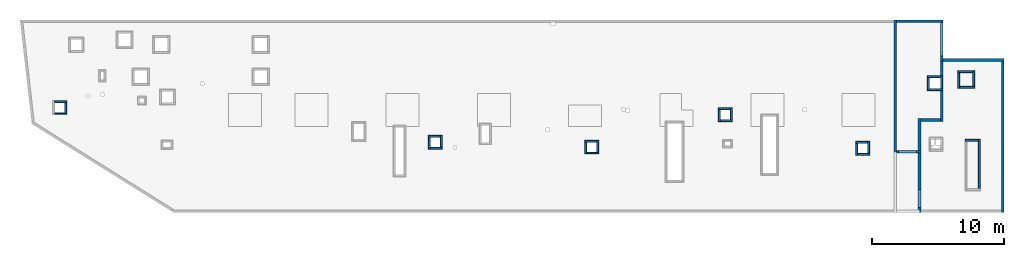
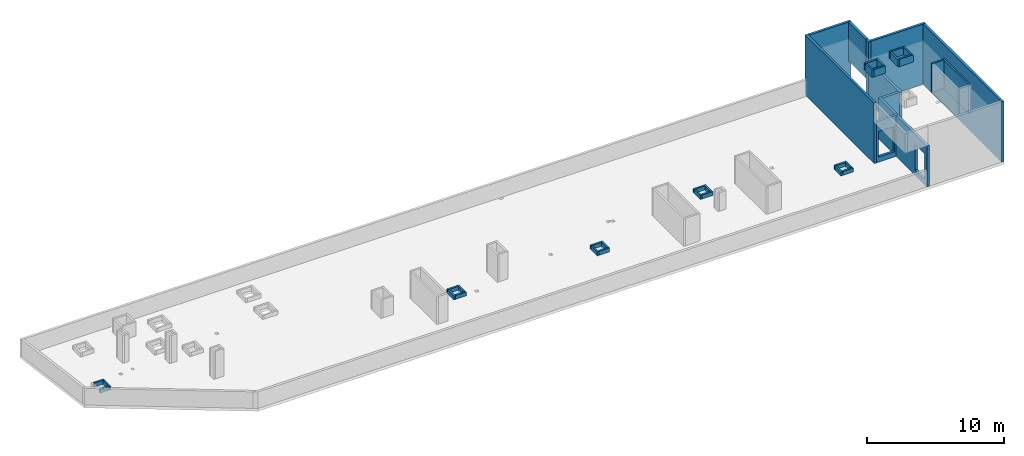
# One storey, part 3 of 3: 40 walls, 2 openings.
"""IFC4 building model written with IfcOpenShell, lengths in millimetres."""

from ifc_helpers import new_model, entity, si_unit, converted_unit, derived_unit, direction, frame, origin, place, context, subcontext, project, spatial, indexed_curve, outline, extrude, polygons, material, type_object, element, save


model = new_model("IFC4")

# Units and contexts
model_context = context("Model", 3, precision=0.01, world=origin(), true_north=direction((6.12303176911189e-17, 1.0)))
plan_context = context("Plan", 3, precision=0.01, world=origin(), true_north=direction((6.12303176911189e-17, 1.0)))
body_context = subcontext(model_context, "Body", "Model", "MODEL_VIEW")
ifc_project = project(units=[si_unit("LENGTHUNIT", "METRE", prefix="MILLI"), si_unit("AREAUNIT", "SQUARE_METRE"), si_unit("VOLUMEUNIT", "CUBIC_METRE"), converted_unit("PLANEANGLEUNIT", "DEGREE", entity("IfcRatioMeasure", 0.0174532925199433), si_unit("PLANEANGLEUNIT", "RADIAN"), dimensions=[0, 0, 0, 0, 0, 0, 0]), si_unit("MASSUNIT", "GRAM", prefix="KILO"), derived_unit("MASSDENSITYUNIT", [(si_unit("MASSUNIT", "GRAM", prefix="KILO"), 1), (si_unit("LENGTHUNIT", "METRE"), -3)]), derived_unit("MOMENTOFINERTIAUNIT", [(si_unit("LENGTHUNIT", "METRE"), 4)]), si_unit("TIMEUNIT", "SECOND"), si_unit("FREQUENCYUNIT", "HERTZ"), si_unit("THERMODYNAMICTEMPERATUREUNIT", "DEGREE_CELSIUS"), derived_unit("THERMALTRANSMITTANCEUNIT", [(si_unit("MASSUNIT", "GRAM", prefix="KILO"), 1), (si_unit("THERMODYNAMICTEMPERATUREUNIT", "KELVIN"), -1), (si_unit("TIMEUNIT", "SECOND"), -3)]), derived_unit("VOLUMETRICFLOWRATEUNIT", [(si_unit("LENGTHUNIT", "METRE"), 3), (si_unit("TIMEUNIT", "SECOND"), -1)]), derived_unit("MASSFLOWRATEUNIT", [(si_unit("MASSUNIT", "GRAM", prefix="KILO"), 1), (si_unit("TIMEUNIT", "SECOND"), -1)]), derived_unit("ROTATIONALFREQUENCYUNIT", [(si_unit("TIMEUNIT", "SECOND"), -1)]), si_unit("ELECTRICCURRENTUNIT", "AMPERE"), si_unit("ELECTRICVOLTAGEUNIT", "VOLT"), si_unit("POWERUNIT", "WATT"), si_unit("FORCEUNIT", "NEWTON", prefix="KILO"), si_unit("ILLUMINANCEUNIT", "LUX"), si_unit("LUMINOUSFLUXUNIT", "LUMEN"), si_unit("LUMINOUSINTENSITYUNIT", "CANDELA"), derived_unit("USERDEFINED", [(si_unit("MASSUNIT", "GRAM", prefix="KILO"), -1), (si_unit("LENGTHUNIT", "METRE"), -2), (si_unit("TIMEUNIT", "SECOND"), 3), (si_unit("LUMINOUSFLUXUNIT", "LUMEN"), 1)]), derived_unit("LINEARVELOCITYUNIT", [(si_unit("LENGTHUNIT", "METRE"), 1), (si_unit("TIMEUNIT", "SECOND"), -1)]), si_unit("PRESSUREUNIT", "PASCAL"), derived_unit("USERDEFINED", [(si_unit("LENGTHUNIT", "METRE"), -2), (si_unit("MASSUNIT", "GRAM", prefix="KILO"), 1), (si_unit("TIMEUNIT", "SECOND"), -2)]), derived_unit("LINEARFORCEUNIT", [(si_unit("MASSUNIT", "GRAM", prefix="KILO"), 1), (si_unit("LENGTHUNIT", "METRE"), 1), (si_unit("TIMEUNIT", "SECOND"), -2), (si_unit("LENGTHUNIT", "METRE"), -1)]), derived_unit("PLANARFORCEUNIT", [(si_unit("MASSUNIT", "GRAM", prefix="KILO"), 1), (si_unit("LENGTHUNIT", "METRE"), 1), (si_unit("TIMEUNIT", "SECOND"), -2), (si_unit("LENGTHUNIT", "METRE"), -2)])], contexts=[model_context, plan_context])

# Site, building, storey
site_placement = place(None, origin())
site = spatial("IfcSite", under=ifc_project, at=site_placement, CompositionType="ELEMENT")
building_placement = place(site_placement, origin())
building = spatial("IfcBuilding", under=site, at=building_placement, CompositionType="ELEMENT")
storey_placement = place(building_placement, frame((0.0, 0.0, 32250.0)))
storey = spatial("IfcBuildingStorey", under=building, at=storey_placement, CompositionType="ELEMENT", Elevation=32250.0)

# Walls
ifc_material = material()
wall_type_1 = type_object("IfcWallType", Name=":ADSK_ 25_200", PredefinedType="STANDARD")
wall_1_placement = place(storey_placement, frame((68870.0, 20300.0, 1910.0), z_axis=(0.0, 0.0, 1.0), x_axis=(0.0, -1.0, 0.0)))
element("IfcWall", 1, at=wall_1_placement, inside=storey, type_object=wall_type_1, material=ifc_material, Name=":ADSK_ 25_200", ObjectType=":ADSK_ 25_200", PredefinedType="NOTDEFINED", context=body_context, shape_type="SweptSolid", body=[
    extrude(outline(indexed_curve([(2520.0006393672, 100.000000000003), (-3.30646371005458e-13, 100.000000000003), (3.30646371005458e-13, -100.000000000003), (2520.0006393672, -100.000000000004), (2520.0006393672, 100.000000000003)], self_intersect=False)), origin(), (0.0, 0.0, 1.0), 3460.0),
])
wall_2_placement = place(storey_placement, frame((68970.0, 17470.0, 0.0)))
element("IfcWall", 2, at=wall_2_placement, inside=storey, type_object=wall_type_1, material=ifc_material, Name=":ADSK_ 25_200", ObjectType=":ADSK_ 25_200", PredefinedType="NOTDEFINED", context=body_context, shape_type="SweptSolid", body=[
    extrude(outline(indexed_curve([(4599.9991821289, 99.9999999999989), (-3.29568315339594e-13, 99.9999999999989), (3.29568315339594e-13, -99.9999999999989), (4599.9991821289, -99.9999999999989), (4599.9991821289, 99.9999999999989)], self_intersect=False)), origin(), (0.0, 0.0, 1.0), 5370.0),
])
wall_3_placement = place(storey_placement, frame((73470.0, 17370.0, 0.0), z_axis=(0.0, 0.0, 1.0), x_axis=(0.0, -1.0, 0.0)))
element("IfcWall", 3, at=wall_3_placement, inside=storey, type_object=wall_type_1, material=ifc_material, Name=":ADSK_ 25_200", ObjectType=":ADSK_ 25_200", PredefinedType="NOTDEFINED", context=body_context, shape_type="SweptSolid", body=[
    extrude(outline(indexed_curve([(11440.0, 100.000000000003), (-1.48847715367481e-13, 100.000000000003), (1.48847715367481e-13, -100.000000000003), (11440.0, -100.000000000004), (11440.0, 100.000000000003)], self_intersect=False)), origin(), (0.0, 0.0, 1.0), 5370.0),
])
wall_4_placement = place(storey_placement, frame((65330.0, 20500.0, 0.0), z_axis=(0.0, 0.0, 1.0), x_axis=(0.0, -1.0, 0.0)))
element("IfcWall", 4, at=wall_4_placement, inside=storey, type_object=wall_type_1, material=ifc_material, Name=":ADSK_ 25_200", ObjectType=":ADSK_ 25_200", PredefinedType="NOTDEFINED", context=body_context, shape_type="SweptSolid", body=[
    extrude(outline(indexed_curve([(10075.0006393667, 100.000000000004), (-2.66139747748769e-13, 100.000000000003), (2.66139747748769e-13, -100.000000000003), (10075.0006393667, -100.000000000002), (10075.0006393667, 100.000000000004)], self_intersect=False)), origin(), (0.0, 0.0, 1.0), 5370.0),
])
wall_5_placement = place(storey_placement, frame((65430.0, 20400.0, -250.0)))
element("IfcWall", 5, at=wall_5_placement, inside=storey, type_object=wall_type_1, material=ifc_material, Name=":ADSK_ 25_200", ObjectType=":ADSK_ 25_200", PredefinedType="NOTDEFINED", context=body_context, shape_type="SweptSolid", body=[
    extrude(outline(indexed_curve([(3540.00000000006, 99.9999999999974), (-3.22401824874843e-13, 99.9999999999989), (3.22401824874843e-13, -99.9999999999989), (3540.00000000006, -100.000000000001), (3540.00000000006, 99.9999999999974)], self_intersect=False)), origin(), (0.0, 0.0, 1.0), 5620.0),
])

# Wall, opening
wall_6_placement = place(storey_placement, frame((65430.0, 10525.0, 0.0)))
wall_6 = element("IfcWall", 6, at=wall_6_placement, inside=storey, type_object=wall_type_1, material=ifc_material, Name=":ADSK_ 25_200", ObjectType=":ADSK_ 25_200", PredefinedType="NOTDEFINED", context=body_context, shape_type="Tessellation", body=[
    polygons([(-3.15235560919963e-12, -99.9999999999989, 0.0), (1649.99999999999, -99.9999999999989, 0.0), (1849.99999999999, -99.9999999999989, 0.0), (1849.99999999999, -99.9999999999989, 3650.0), (1649.99999999999, -99.9999999999989, 3650.0), (4.88252665971232e-11, -99.9999999999989, 3650.0), (150.000000000006, -99.9999999999989, 2729.99999999805), (1500.00000000001, -99.9999999999989, 2729.99999999805), (1500.0, -99.9999999999989, 450.000000000002), (150.000000000006, -99.9999999999989, 450.000000000002), (1849.99999999999, 100.000000000001, 0.0), (1650.00000000009, 100.000000000001, 0.0), (-3.87761424809092e-12, 100.000000000003, 0.0), (-3.87761424809091e-12, 100.000000000001, 3650.0), (1650.00000000009, 100.000000000001, 3650.0), (1849.99999999999, 100.000000000001, 3650.0), (1500.0, 100.000000000001, 2729.99999999805), (149.999999999997, 100.000000000001, 2729.99999999805), (149.999999999997, 100.000000000001, 450.000000000002), (1500.0, 100.000000000001, 450.000000000002), (-3.51498492864527e-12, 2.16573425859679e-12, 3650.0)], [[[1, 2, 3, 4, 5, 6], [7, 8, 9, 10]], [[11, 12, 13, 14, 15, 16], [17, 18, 19, 20]], [[3, 2, 1, 13, 12, 11]], [[1, 6, 21, 14, 13]], [[4, 3, 11, 16]], [[6, 5, 4, 16, 15, 14, 21]], [[17, 8, 7, 18]], [[18, 7, 10, 19]], [[19, 10, 9, 20]], [[8, 17, 20, 9]]], closed=True),
])
opening_1_placement = place(wall_6_placement, frame((-65430.0, -10525.0, 0.0)))
element("IfcOpeningElement", 7, at=opening_1_placement, cuts=wall_6, Name=":ADSK_ 25_200", PredefinedType="OPENING", context=body_context, shape_type="SweptSolid", body=[
    extrude(outline(indexed_curve([(-1139.99999999902, -674.999999999994), (1139.99999999902, -674.999999999994), (1139.99999999902, 675.000000000003), (-1139.99999999902, 675.000000000003), (-1139.99999999902, -674.999999999994)], self_intersect=False)), frame((66255.0, 10325.0, 1590.0), z_axis=(0.0, 1.0, 0.0), x_axis=(0.0, 0.0, -1.0)), (0.0, 0.0, 1.0), 400.000000001943),
])

wall_7_placement = place(storey_placement, frame((67180.0, 5930.0, 0.0), z_axis=(0.0, 0.0, 1.0), x_axis=(0.0, 1.0, 0.0)))
wall_7 = element("IfcWall", 8, at=wall_7_placement, inside=storey, type_object=wall_type_1, material=ifc_material, Name=":ADSK_ 25_200", ObjectType=":ADSK_ 25_200", PredefinedType="NOTDEFINED", context=body_context, shape_type="Tessellation", body=[
    polygons([(1.08286712929839e-12, -99.9999999999946, 0.0), (200.000000000001, -99.9999999999946, 0.0), (4495.00000000053, -99.9999999999946, 0.0), (4495.00000000053, -99.9999999999946, 3650.0), (199.999999999995, -99.9999999999946, 3650.0), (0.0, -99.9999999999946, 3650.0), (384.999999999998, -99.9999999999946, 2729.99999999805), (1735.0, -99.9999999999946, 2729.99999999805), (1735.0, -99.9999999999946, 450.000000000002), (384.999999999999, -99.9999999999946, 450.000000000002), (4495.00000000053, 100.000000000012, 0.0), (200.000000000001, 100.000000000003, 0.0), (2.16573425859679e-12, 100.000000000012, 0.0), (2.16573425859679e-12, 100.000000000003, 1470.0), (1.08286712929839e-12, 100.000000000012, 3650.0), (199.999999999995, 100.000000000012, 3650.0), (4495.00000000053, 100.000000000012, 3650.0), (1735.0, 100.000000000012, 2729.99999999805), (384.999999999999, 100.000000000012, 2729.99999999805), (384.999999999999, 100.000000000012, 450.000000000002), (1735.0, 100.000000000012, 450.000000000002), (0.0, 0.0, 3650.0)], [[[1, 2, 3, 4, 5, 6], [7, 8, 9, 10]], [[11, 12, 13, 14, 15, 16, 17], [18, 19, 20, 21]], [[3, 2, 1, 13, 12, 11]], [[4, 3, 11, 17]], [[6, 22, 15, 14, 13, 1]], [[15, 22, 6, 5, 16]], [[5, 4, 17, 16]], [[7, 19, 18, 8]], [[8, 18, 21, 9]], [[9, 21, 20, 10]], [[19, 7, 10, 20]]], closed=True),
])
opening_2_placement = place(wall_7_placement, frame((-5930.0, 67180.0, 0.0), z_axis=(0.0, 0.0, 1.0), x_axis=(0.0, -1.0, 0.0)))
element("IfcOpeningElement", 9, at=opening_2_placement, cuts=wall_7, Name=":ADSK_ 25_200", PredefinedType="OPENING", context=body_context, shape_type="SweptSolid", body=[
    extrude(outline(indexed_curve([(-674.999999999999, -1139.99999999902), (675.0, -1139.99999999902), (675.0, 1139.99999999902), (-674.999999999999, 1139.99999999902), (-674.999999999999, -1139.99999999902)], self_intersect=False)), frame((67380.0, 6990.0, 1590.0), z_axis=(-1.0, 0.0, 0.0), x_axis=(0.0, 1.0, 0.0)), (0.0, 0.0, 1.0), 400.000000001936),
])

# Walls
wall_8_placement = place(storey_placement, frame((68870.0, 17780.0, -250.0), z_axis=(0.0, 0.0, 1.0), x_axis=(0.0, -1.0, 0.0)))
element("IfcWall", 10, at=wall_8_placement, inside=storey, type_object=wall_type_1, material=ifc_material, Name=":ADSK_ 25_200", ObjectType=":ADSK_ 25_200", PredefinedType="NOTDEFINED", context=body_context, shape_type="Tessellation", body=[
    polygons([(409.999999999996, -99.9999999999946, 5620.0), (2.16573425859679e-12, -99.9999999999946, 5620.0), (0.0, -99.9999999999946, 2160.0), (2.16573425859679e-12, -99.9999999999946, 4.33146851719357e-12), (210.000000000006, -99.9999999999946, 4.33146851719357e-12), (210.000000000006, -99.9999999999946, 250.000000000004), (409.999999999996, -99.9999999999946, 250.000000000004), (409.999999999996, -99.9999999999946, 3900.00000000001), (2.16573425859679e-12, 100.000000000003, 5620.0), (209.999999999996, 100.000000000003, 5620.0), (409.999999999996, 100.000000000003, 5620.0), (409.999999999996, 100.000000000003, 3900.00000000001), (409.999999999996, 100.000000000003, 250.000000000004), (210.000000000006, 100.000000000003, 250.000000000004), (210.000000000006, 100.000000000003, 4.33146851719357e-12), (2.16573425859679e-12, 100.000000000003, 4.33146851719357e-12), (0.0, 100.000000000003, 2160.0)], [[[1, 2, 3, 4, 5, 6, 7, 8]], [[9, 10, 11, 12, 13, 14, 15, 16, 17]], [[4, 16, 15, 5]], [[2, 1, 11, 10, 9]], [[4, 3, 2, 9, 17, 16]], [[11, 1, 8, 7, 13, 12]], [[6, 14, 13, 7]], [[14, 6, 5, 15]]], closed=True),
])
wall_9_placement = place(storey_placement, frame((67180.0, 10625.0, 0.0), z_axis=(0.0, 0.0, 1.0), x_axis=(0.0, 1.0, 0.0)))
element("IfcWall", 11, at=wall_9_placement, inside=storey, type_object=wall_type_1, material=ifc_material, Name=":ADSK_ 25_200", ObjectType=":ADSK_ 25_200", PredefinedType="NOTDEFINED", context=body_context, shape_type="Tessellation", body=[
    polygons([(0.0, -99.9999999999859, 0.0), (2204.99999999949, -99.9999999999946, 0.0), (2404.99999999949, -99.9999999999859, 0.0), (2404.99999999949, -99.9999999999859, 3650.0), (2204.99999999949, -99.9999999999946, 3650.0), (0.0, -99.9999999999859, 3650.0), (2.16573425859679e-12, 100.000000000003, 0.0), (2.16573425859679e-12, 100.000000000003, 3650.0), (2404.99999999949, 100.000000000003, 3650.0), (2404.99999999949, 100.000000000003, 0.0)], [[[1, 2, 3, 4, 5, 6]], [[7, 8, 9, 10]], [[3, 2, 1, 7, 10]], [[4, 3, 10, 9]], [[1, 6, 8, 7]], [[6, 5, 4, 9, 8]]], closed=True),
])
wall_10_placement = place(storey_placement, frame((68870.0, 17370.0, 0.0), z_axis=(0.0, 0.0, 1.0), x_axis=(0.0, -1.0, 0.0)))
element("IfcWall", 12, at=wall_10_placement, inside=storey, type_object=wall_type_1, material=ifc_material, Name=":ADSK_ 25_200", ObjectType=":ADSK_ 25_200", PredefinedType="NOTDEFINED", context=body_context, shape_type="Tessellation", body=[
    polygons([(0.0, -99.9999999999954, 0.0), (4339.99999999999, -99.9999999999952, 0.0), (4539.99999999999, -99.9999999999948, 0.0), (4539.99999999999, -99.9999999999948, 3650.0), (4339.99999999999, -99.9999999999952, 3650.0), (0.0, -99.9999999999954, 3650.0), (0.0, 100.000000000011, 0.0), (0.0, 100.000000000011, 3650.0), (4539.99999999999, 100.000000000003, 3650.0), (4539.99999999999, 100.000000000003, 0.0)], [[[1, 2, 3, 4, 5, 6]], [[7, 8, 9, 10]], [[3, 2, 1, 7, 10]], [[4, 3, 10, 9]], [[1, 6, 8, 7]], [[6, 5, 4, 9, 8]]], closed=True),
])
wall_11_placement = place(storey_placement, frame((68770.0, 12930.0, 0.0), z_axis=(0.0, 0.0, 1.0), x_axis=(-1.0, 0.0, 0.0)))
element("IfcWall", 13, at=wall_11_placement, inside=storey, type_object=wall_type_1, material=ifc_material, Name=":ADSK_ 25_200", ObjectType=":ADSK_ 25_200", PredefinedType="NOTDEFINED", context=body_context, shape_type="Tessellation", body=[
    polygons([(2.74677004661093e-12, -100.000000000001, 0.0), (1489.99999999997, -100.000000000001, 0.0), (1489.99999999997, -100.000000000001, 3650.0), (2.74677004661093e-12, -100.000000000001, 3650.0), (2.17273289534979e-12, 99.9999999999989, 0.0), (2.17273289534979e-12, 99.9999999999989, 3650.0), (1489.99999999997, 99.9999999999989, 3650.0), (1489.99999999997, 99.9999999999989, 0.0)], [[[1, 2, 3, 4]], [[5, 6, 7, 8]], [[2, 1, 5, 8]], [[1, 4, 6, 5]], [[3, 2, 8, 7]], [[4, 3, 7, 6]]], closed=True),
])
wall_type_2 = type_object("IfcWallType", Name=":ADSK_ 25_150", PredefinedType="STANDARD")
wall_12_placement = place(storey_placement, frame((1735.0, 14325.0, 0.0)))
element("IfcWall", 14, at=wall_12_placement, inside=storey, type_object=wall_type_2, material=ifc_material, Name=":ADSK_ 25_150", ObjectType=":ADSK_ 25_150", PredefinedType="NOTDEFINED", context=body_context, shape_type="SweptSolid", body=[
    extrude(outline(indexed_curve([(900.0, 75.0000000000007), (5.41433564649185e-14, 75.0000000000003), (-5.41433564649185e-14, -75.0000000000003), (900.0, -74.9999999999998), (900.0, 75.0000000000007)], self_intersect=False)), origin(), (0.0, 0.0, 1.0), 349.999999999998),
])
wall_13_placement = place(storey_placement, frame((2560.0, 14250.0, 0.0), z_axis=(0.0, 0.0, 1.0), x_axis=(0.0, -1.0, 0.0)))
element("IfcWall", 15, at=wall_13_placement, inside=storey, type_object=wall_type_2, material=ifc_material, Name=":ADSK_ 25_150", ObjectType=":ADSK_ 25_150", PredefinedType="NOTDEFINED", context=body_context, shape_type="SweptSolid", body=[
    extrude(outline(indexed_curve([(900.000000000001, 75.0000000000005), (-1.0828671292984e-13, 75.0000000000003), (1.0828671292984e-13, -75.0000000000003), (900.000000000001, -75.0000000000001), (900.000000000001, 75.0000000000005)], self_intersect=False)), origin(), (0.0, 0.0, 1.0), 349.999999999998),
])
wall_14_placement = place(storey_placement, frame((2485.0, 13425.0, 0.0), z_axis=(0.0, 0.0, 1.0), x_axis=(-1.0, 0.0, 0.0)))
element("IfcWall", 16, at=wall_14_placement, inside=storey, type_object=wall_type_2, material=ifc_material, Name=":ADSK_ 25_150", ObjectType=":ADSK_ 25_150", PredefinedType="NOTDEFINED", context=body_context, shape_type="SweptSolid", body=[
    extrude(outline(indexed_curve([(750.0, 75.0000000000003), (0.0, 75.0000000000003), (0.0, -75.0000000000003), (750.0, -75.0000000000003), (750.0, 75.0000000000003)], self_intersect=False)), origin(), (0.0, 0.0, 1.0), 349.999999999998),
])
wall_15_placement = place(storey_placement, frame((30010.0, 11710.0, 0.0)))
element("IfcWall", 17, at=wall_15_placement, inside=storey, type_object=wall_type_2, material=ifc_material, Name=":ADSK_ 25_150", ObjectType=":ADSK_ 25_150", PredefinedType="NOTDEFINED", context=body_context, shape_type="SweptSolid", body=[
    extrude(outline(indexed_curve([(900.000000000003, 75.0000000000003), (0.0, 75.0000000000003), (0.0, -75.0000000000003), (900.000000000003, -75.0000000000003), (900.000000000003, 75.0000000000003)], self_intersect=False)), origin(), (0.0, 0.0, 1.0), 349.999999999998),
])
for number, where, z_axis, x_axis, name in (
    (18, (30085.0, 10735.0, 0.0), (0.0, 0.0, 1.0), (0.0, 1.0, 0.0), ":ADSK_ 25_150"),
    (19, (31060.0, 10810.0, 0.0), (0.0, 0.0, 1.0), (-1.0, 0.0, 0.0), ":ADSK_ 25_150"),
    (20, (30985.0, 11785.0, 0.0), (0.0, 0.0, 1.0), (0.0, -1.0, 0.0), ":ADSK_ 25_150"),
):
    element("IfcWall", number, at=place(storey_placement, frame(where, z_axis=z_axis, x_axis=x_axis)), inside=storey, type_object=wall_type_2, material=ifc_material, Name=name, ObjectType=":ADSK_ 25_150", PredefinedType="NOTDEFINED", context=body_context, shape_type="SweptSolid", body=[
        extrude(outline(indexed_curve([(900.000000000003, 75.0000000000003), (0.0, 75.0000000000003), (0.0, -75.0000000000003), (900.000000000003, -75.0000000000003), (900.000000000003, 75.0000000000003)], self_intersect=False)), origin(), (0.0, 0.0, 1.0), 349.999999999998),
    ])
wall_16_placement = place(storey_placement, frame((41860.0, 11335.0, 0.0)))
element("IfcWall", 21, at=wall_16_placement, inside=storey, type_object=wall_type_2, material=ifc_material, Name=":ADSK_ 25_150", ObjectType=":ADSK_ 25_150", PredefinedType="NOTDEFINED", context=body_context, shape_type="SweptSolid", body=[
    extrude(outline(indexed_curve([(900.000000000012, 75.0000000000003), (0.0, 75.0000000000003), (0.0, -75.0000000000003), (900.000000000012, -75.0000000000003), (900.000000000012, 75.0000000000003)], self_intersect=False)), origin(), (0.0, 0.0, 1.0), 349.999999999998),
])
wall_17_placement = place(storey_placement, frame((41935.0, 10360.0, 0.0), z_axis=(0.0, 0.0, 1.0), x_axis=(0.0, 1.0, 0.0)))
element("IfcWall", 22, at=wall_17_placement, inside=storey, type_object=wall_type_2, material=ifc_material, Name=":ADSK_ 25_150", ObjectType=":ADSK_ 25_150", PredefinedType="NOTDEFINED", context=body_context, shape_type="SweptSolid", body=[
    extrude(outline(indexed_curve([(899.999999999995, 75.0000000000003), (0.0, 75.0000000000003), (0.0, -75.0000000000003), (899.999999999995, -75.0000000000003), (899.999999999995, 75.0000000000003)], self_intersect=False)), origin(), (0.0, 0.0, 1.0), 349.999999999998),
])
wall_18_placement = place(storey_placement, frame((42910.0, 10435.0, 0.0), z_axis=(0.0, 0.0, 1.0), x_axis=(-1.0, 0.0, 0.0)))
element("IfcWall", 23, at=wall_18_placement, inside=storey, type_object=wall_type_2, material=ifc_material, Name=":ADSK_ 25_150", ObjectType=":ADSK_ 25_150", PredefinedType="NOTDEFINED", context=body_context, shape_type="SweptSolid", body=[
    extrude(outline(indexed_curve([(900.000000000012, 75.0000000000003), (0.0, 75.0000000000003), (0.0, -75.0000000000003), (900.000000000012, -75.0000000000003), (900.000000000012, 75.0000000000003)], self_intersect=False)), origin(), (0.0, 0.0, 1.0), 349.999999999998),
])
wall_19_placement = place(storey_placement, frame((42835.0, 11410.0, 0.0), z_axis=(0.0, 0.0, 1.0), x_axis=(0.0, -1.0, 0.0)))
element("IfcWall", 24, at=wall_19_placement, inside=storey, type_object=wall_type_2, material=ifc_material, Name=":ADSK_ 25_150", ObjectType=":ADSK_ 25_150", PredefinedType="NOTDEFINED", context=body_context, shape_type="SweptSolid", body=[
    extrude(outline(indexed_curve([(899.999999999995, 75.0000000000003), (0.0, 75.0000000000003), (0.0, -75.0000000000003), (899.999999999995, -75.0000000000003), (899.999999999995, 75.0000000000003)], self_intersect=False)), origin(), (0.0, 0.0, 1.0), 349.999999999998),
])
wall_20_placement = place(storey_placement, frame((51960.0, 13775.0, 0.0)))
element("IfcWall", 25, at=wall_20_placement, inside=storey, type_object=wall_type_2, material=ifc_material, Name=":ADSK_ 25_150", ObjectType=":ADSK_ 25_150", PredefinedType="NOTDEFINED", context=body_context, shape_type="SweptSolid", body=[
    extrude(outline(indexed_curve([(900.000000000012, 75.0000000000003), (0.0, 75.0000000000003), (0.0, -75.0000000000003), (900.000000000012, -75.0000000000003), (900.000000000012, 75.0000000000003)], self_intersect=False)), origin(), (0.0, 0.0, 1.0), 349.999999999998),
])
wall_21_placement = place(storey_placement, frame((52035.0, 12800.0, 0.0), z_axis=(0.0, 0.0, 1.0), x_axis=(0.0, 1.0, 0.0)))
element("IfcWall", 26, at=wall_21_placement, inside=storey, type_object=wall_type_2, material=ifc_material, Name=":ADSK_ 25_150", ObjectType=":ADSK_ 25_150", PredefinedType="NOTDEFINED", context=body_context, shape_type="SweptSolid", body=[
    extrude(outline(indexed_curve([(900.000000000008, 75.0000000000003), (0.0, 75.0000000000003), (0.0, -75.0000000000003), (900.000000000008, -75.0000000000003), (900.000000000008, 75.0000000000003)], self_intersect=False)), origin(), (0.0, 0.0, 1.0), 349.999999999998),
])
wall_22_placement = place(storey_placement, frame((53010.0, 12875.0, 0.0), z_axis=(0.0, 0.0, 1.0), x_axis=(-1.0, 0.0, 0.0)))
element("IfcWall", 27, at=wall_22_placement, inside=storey, type_object=wall_type_2, material=ifc_material, Name=":ADSK_ 25_150", ObjectType=":ADSK_ 25_150", PredefinedType="NOTDEFINED", context=body_context, shape_type="SweptSolid", body=[
    extrude(outline(indexed_curve([(900.000000000012, 75.0000000000003), (0.0, 75.0000000000003), (0.0, -75.0000000000003), (900.000000000012, -75.0000000000003), (900.000000000012, 75.0000000000003)], self_intersect=False)), origin(), (0.0, 0.0, 1.0), 349.999999999998),
])
wall_23_placement = place(storey_placement, frame((52935.0, 13850.0, 0.0), z_axis=(0.0, 0.0, 1.0), x_axis=(0.0, -1.0, 0.0)))
element("IfcWall", 28, at=wall_23_placement, inside=storey, type_object=wall_type_2, material=ifc_material, Name=":ADSK_ 25_150", ObjectType=":ADSK_ 25_150", PredefinedType="NOTDEFINED", context=body_context, shape_type="SweptSolid", body=[
    extrude(outline(indexed_curve([(900.000000000008, 75.0000000000003), (0.0, 75.0000000000003), (0.0, -75.0000000000003), (900.000000000008, -75.0000000000003), (900.000000000008, 75.0000000000003)], self_intersect=False)), origin(), (0.0, 0.0, 1.0), 349.999999999998),
])
wall_24_placement = place(storey_placement, frame((62345.0, 11235.0, 0.0)))
element("IfcWall", 29, at=wall_24_placement, inside=storey, type_object=wall_type_2, material=ifc_material, Name=":ADSK_ 25_150", ObjectType=":ADSK_ 25_150", PredefinedType="NOTDEFINED", context=body_context, shape_type="SweptSolid", body=[
    extrude(outline(indexed_curve([(899.999999999995, 75.0000000000003), (0.0, 75.0000000000003), (0.0, -75.0000000000003), (899.999999999995, -75.0000000000003), (899.999999999995, 75.0000000000003)], self_intersect=False)), origin(), (0.0, 0.0, 1.0), 349.999999999998),
])
wall_25_placement = place(storey_placement, frame((62420.0, 10260.0, 0.0), z_axis=(0.0, 0.0, 1.0), x_axis=(0.0, 1.0, 0.0)))
element("IfcWall", 30, at=wall_25_placement, inside=storey, type_object=wall_type_2, material=ifc_material, Name=":ADSK_ 25_150", ObjectType=":ADSK_ 25_150", PredefinedType="NOTDEFINED", context=body_context, shape_type="SweptSolid", body=[
    extrude(outline(indexed_curve([(900.00000000001, 75.0000000000003), (0.0, 75.0000000000003), (0.0, -75.0000000000003), (900.00000000001, -75.0000000000003), (900.00000000001, 75.0000000000003)], self_intersect=False)), origin(), (0.0, 0.0, 1.0), 349.999999999998),
])
wall_26_placement = place(storey_placement, frame((63395.0, 10335.0, 0.0), z_axis=(0.0, 0.0, 1.0), x_axis=(-1.0, 0.0, 0.0)))
element("IfcWall", 31, at=wall_26_placement, inside=storey, type_object=wall_type_2, material=ifc_material, Name=":ADSK_ 25_150", ObjectType=":ADSK_ 25_150", PredefinedType="NOTDEFINED", context=body_context, shape_type="SweptSolid", body=[
    extrude(outline(indexed_curve([(899.999999999995, 75.0000000000003), (0.0, 75.0000000000003), (0.0, -75.0000000000003), (899.999999999995, -75.0000000000003), (899.999999999995, 75.0000000000003)], self_intersect=False)), origin(), (0.0, 0.0, 1.0), 349.999999999998),
])
wall_27_placement = place(storey_placement, frame((63320.0, 11310.0, 0.0), z_axis=(0.0, 0.0, 1.0), x_axis=(0.0, -1.0, 0.0)))
element("IfcWall", 32, at=wall_27_placement, inside=storey, type_object=wall_type_2, material=ifc_material, Name=":ADSK_ 25_150", ObjectType=":ADSK_ 25_150", PredefinedType="NOTDEFINED", context=body_context, shape_type="SweptSolid", body=[
    extrude(outline(indexed_curve([(900.00000000001, 75.0000000000003), (0.0, 75.0000000000003), (0.0, -75.0000000000003), (900.00000000001, -75.0000000000003), (900.00000000001, 75.0000000000003)], self_intersect=False)), origin(), (0.0, 0.0, 1.0), 349.999999999998),
])
wall_28_placement = place(storey_placement, frame((70620.0, 11390.0, 3900.0)))
element("IfcWall", 33, at=wall_28_placement, inside=storey, type_object=wall_type_2, material=ifc_material, Name=":ADSK_ 25_150", ObjectType=":ADSK_ 25_150", PredefinedType="NOTDEFINED", context=body_context, shape_type="SweptSolid", body=[
    extrude(outline(indexed_curve([(999.999999999981, 75.0000000000003), (0.0, 75.0000000000003), (0.0, -75.0000000000003), (999.999999999981, -75.0000000000003), (999.999999999981, 75.0000000000003)], self_intersect=False)), origin(), (0.0, 0.0, 1.0), 2550.0),
])
wall_29_placement = place(storey_placement, frame((71695.0, 11465.0, 3900.0), z_axis=(0.0, 0.0, 1.0), x_axis=(0.0, -1.0, 0.0)))
element("IfcWall", 34, at=wall_29_placement, inside=storey, type_object=wall_type_2, material=ifc_material, Name=":ADSK_ 25_150", ObjectType=":ADSK_ 25_150", PredefinedType="NOTDEFINED", context=body_context, shape_type="SweptSolid", body=[
    extrude(outline(indexed_curve([(3750.00000000001, 74.9999999999918), (3.41958040831072e-13, 75.0000000000003), (-3.41958040831072e-13, -75.0000000000003), (3750.0, -75.0000000000087), (3750.00000000001, 74.9999999999918)], self_intersect=False)), origin(), (0.0, 0.0, 1.0), 2550.0),
])
wall_30_placement = place(storey_placement, frame((67770.0, 16215.0, 3900.0)))
element("IfcWall", 35, at=wall_30_placement, inside=storey, type_object=wall_type_2, material=ifc_material, Name=":ADSK_ 25_150", ObjectType=":ADSK_ 25_150", PredefinedType="NOTDEFINED", context=body_context, shape_type="SweptSolid", body=[
    extrude(outline(indexed_curve([(999.999999999998, 75.0000000000003), (0.0, 75.0000000000003), (0.0, -75.0000000000003), (999.999999999998, -75.0000000000003), (999.999999999998, 75.0000000000003)], self_intersect=False)), origin(), (0.0, 0.0, 1.0), 650.0),
])
wall_31_placement = place(storey_placement, frame((67845.0, 15140.0, 3900.0), z_axis=(0.0, 0.0, 1.0), x_axis=(0.0, 1.0, 0.0)))
element("IfcWall", 36, at=wall_31_placement, inside=storey, type_object=wall_type_2, material=ifc_material, Name=":ADSK_ 25_150", ObjectType=":ADSK_ 25_150", PredefinedType="NOTDEFINED", context=body_context, shape_type="SweptSolid", body=[
    extrude(outline(indexed_curve([(1000.0, 75.0000000000003), (0.0, 75.0000000000003), (0.0, -75.0000000000003), (1000.0, -75.0000000000003), (1000.0, 75.0000000000003)], self_intersect=False)), origin(), (0.0, 0.0, 1.0), 650.0),
])
wall_32_placement = place(storey_placement, frame((68920.0, 15215.0, 3900.0), z_axis=(0.0, 0.0, 1.0), x_axis=(-1.0, 0.0, 0.0)))
element("IfcWall", 37, at=wall_32_placement, inside=storey, type_object=wall_type_2, material=ifc_material, Name=":ADSK_ 25_150", ObjectType=":ADSK_ 25_150", PredefinedType="NOTDEFINED", context=body_context, shape_type="SweptSolid", body=[
    extrude(outline(indexed_curve([(999.999999999998, 75.0000000000003), (0.0, 75.0000000000003), (0.0, -75.0000000000003), (999.999999999998, -75.0000000000003), (999.999999999998, 75.0000000000003)], self_intersect=False)), origin(), (0.0, 0.0, 1.0), 650.0),
])
wall_33_placement = place(storey_placement, frame((68845.0, 16290.0, 3900.0), z_axis=(0.0, 0.0, 1.0), x_axis=(0.0, -1.0, 0.0)))
element("IfcWall", 38, at=wall_33_placement, inside=storey, type_object=wall_type_2, material=ifc_material, Name=":ADSK_ 25_150", ObjectType=":ADSK_ 25_150", PredefinedType="NOTDEFINED", context=body_context, shape_type="SweptSolid", body=[
    extrude(outline(indexed_curve([(1000.0, 75.0000000000003), (0.0, 75.0000000000003), (0.0, -75.0000000000003), (1000.0, -75.0000000000003), (1000.0, 75.0000000000003)], self_intersect=False)), origin(), (0.0, 0.0, 1.0), 650.0),
])
wall_34_placement = place(storey_placement, frame((70070.0, 16575.0, 3900.0)))
element("IfcWall", 39, at=wall_34_placement, inside=storey, type_object=wall_type_2, material=ifc_material, Name=":ADSK_ 25_150", ObjectType=":ADSK_ 25_150", PredefinedType="NOTDEFINED", context=body_context, shape_type="SweptSolid", body=[
    extrude(outline(indexed_curve([(1150.0, 75.0000000000003), (0.0, 75.0000000000003), (0.0, -75.0000000000003), (1150.0, -75.0000000000003), (1150.0, 75.0000000000003)], self_intersect=False)), origin(), (0.0, 0.0, 1.0), 650.0),
])
wall_35_placement = place(storey_placement, frame((70145.0, 15350.0, 3900.0), z_axis=(0.0, 0.0, 1.0), x_axis=(0.0, 1.0, 0.0)))
element("IfcWall", 40, at=wall_35_placement, inside=storey, type_object=wall_type_2, material=ifc_material, Name=":ADSK_ 25_150", ObjectType=":ADSK_ 25_150", PredefinedType="NOTDEFINED", context=body_context, shape_type="SweptSolid", body=[
    extrude(outline(indexed_curve([(1150.0, 75.0000000000003), (0.0, 75.0000000000003), (0.0, -75.0000000000003), (1150.0, -75.0000000000003), (1150.0, 75.0000000000003)], self_intersect=False)), origin(), (0.0, 0.0, 1.0), 650.0),
])
wall_36_placement = place(storey_placement, frame((71370.0, 15425.0, 3900.0), z_axis=(0.0, 0.0, 1.0), x_axis=(-1.0, 0.0, 0.0)))
element("IfcWall", 41, at=wall_36_placement, inside=storey, type_object=wall_type_2, material=ifc_material, Name=":ADSK_ 25_150", ObjectType=":ADSK_ 25_150", PredefinedType="NOTDEFINED", context=body_context, shape_type="SweptSolid", body=[
    extrude(outline(indexed_curve([(1150.0, 74.9999999999999), (-1.16021478139114e-13, 75.0000000000003), (1.16021478139114e-13, -75.0000000000003), (1150.0, -75.0000000000007), (1150.0, 74.9999999999999)], self_intersect=False)), origin(), (0.0, 0.0, 1.0), 650.0),
])
wall_37_placement = place(storey_placement, frame((71295.0, 16650.0, 3900.0), z_axis=(0.0, 0.0, 1.0), x_axis=(0.0, -1.0, 0.0)))
element("IfcWall", 42, at=wall_37_placement, inside=storey, type_object=wall_type_2, material=ifc_material, Name=":ADSK_ 25_150", ObjectType=":ADSK_ 25_150", PredefinedType="NOTDEFINED", context=body_context, shape_type="SweptSolid", body=[
    extrude(outline(indexed_curve([(1150.0, 75.0000000000003), (0.0, 75.0000000000003), (0.0, -75.0000000000003), (1150.0, -75.0000000000003), (1150.0, 75.0000000000003)], self_intersect=False)), origin(), (0.0, 0.0, 1.0), 650.0),
])

save(model, "model.ifc")
